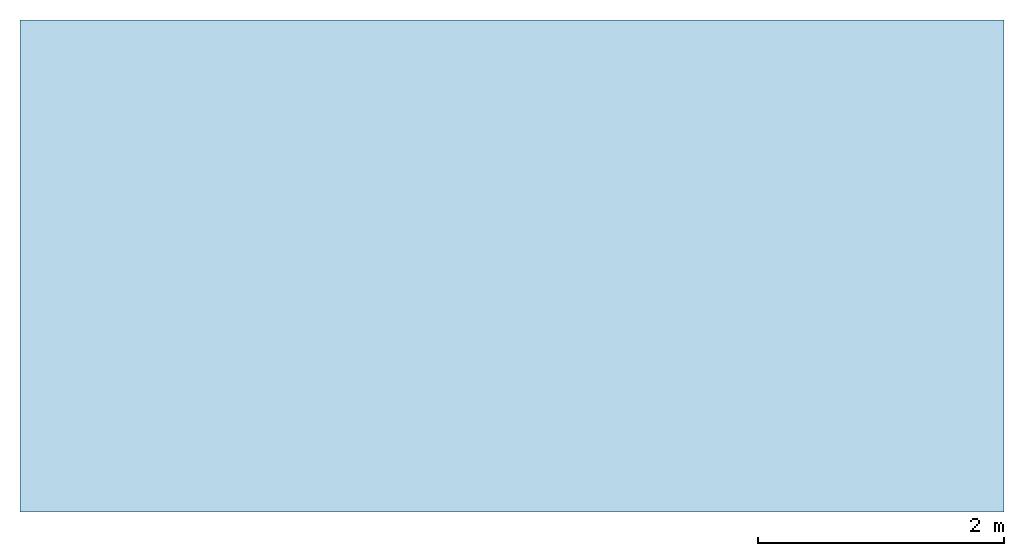
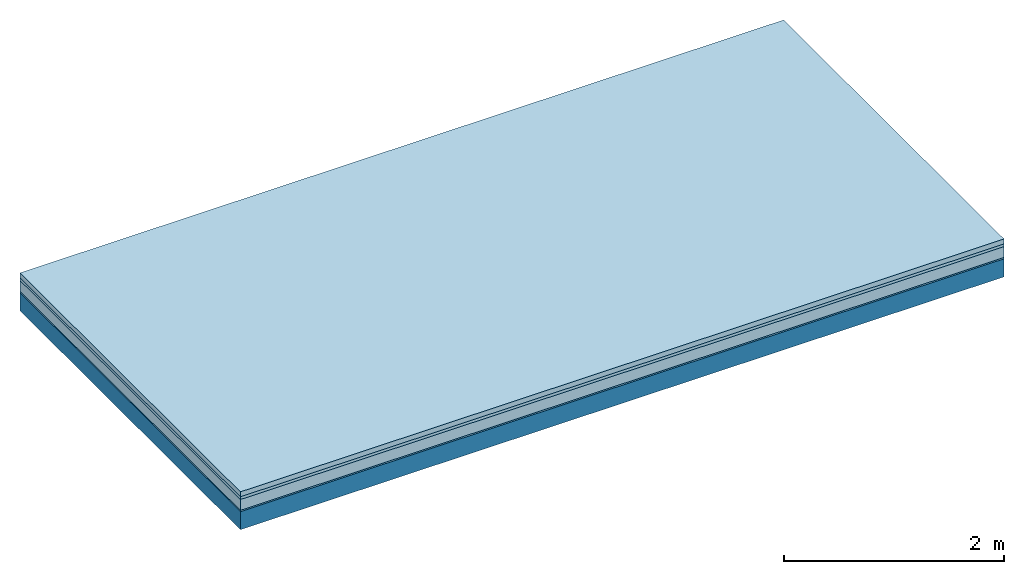
# One storey: 4 plates, 1 member, 1 element without a shape of its own.
"""IFC4 building model written with IfcOpenShell, lengths in metres."""

from ifc_helpers import new_model, si_unit, derived_unit, direction, frame, frame_2d, origin, origin_with_axes, place, context, project, spatial, rectangle, extrude, material, layer, layer_set, type_object, element, aggregate, save


model = new_model("IFC4")

# Units and contexts
plan_context = context("Plan", 3, precision=1e-05, world=origin(), true_north=direction((0.0, 1.0)))
model_context = context("Model", 3, precision=1e-05, world=origin(), true_north=direction((0.0, 1.0)))
ifc_project = project(units=[si_unit("LENGTHUNIT", "METRE"), derived_unit("SOUNDPRESSUREUNIT", [(si_unit("PRESSUREUNIT", "PASCAL", prefix="MICRO"), 0)]), si_unit("ENERGYUNIT", "JOULE", prefix="MEGA"), si_unit("MASSUNIT", "GRAM", prefix="KILO"), derived_unit("THERMALTRANSMITTANCEUNIT", [(si_unit("POWERUNIT", "WATT"), 1), (si_unit("AREAUNIT", "SQUARE_METRE"), -1), (si_unit("THERMODYNAMICTEMPERATUREUNIT", "KELVIN"), -1)]), derived_unit("AREADENSITYUNIT", [(si_unit("MASSUNIT", "GRAM", prefix="KILO"), 1), (si_unit("AREAUNIT", "SQUARE_METRE"), -1)]), derived_unit("USERDEFINED", [(si_unit("ENERGYUNIT", "JOULE", prefix="MEGA"), 1), (si_unit("AREAUNIT", "SQUARE_METRE"), -1)])], contexts=[plan_context, model_context])

# Site, building, storey
site = spatial("IfcSite", under=ifc_project)
building_placement = place(None, origin())
building = spatial("IfcBuilding", under=site, at=building_placement)
storey_placement = place(building_placement, origin())
storey = spatial("IfcBuildingStorey", under=building, at=storey_placement)

# Slab, member, plates
ifc_material_1 = material(Category="04.005")
ifc_layer_1 = layer(ifc_material_1, 0.055, Name="On-material")
ifc_material_2 = material()
ifc_layer_2 = layer(ifc_material_2, 0.03, Name="Impact sound insulation")
ifc_material_3 = material(Category="03.011")
ifc_layer_3 = layer(ifc_material_3, 0.12, Name="on Supporting structure")
ifc_material_4 = material(Category="03.007")
ifc_layer_4 = layer(ifc_material_4, 0.015, Name="Sub-floor")
ifc_material_5 = material(Name="of the art")
ifc_layer_5 = layer(ifc_material_5, 0.0, Name="Bond")
ifc_layer_6 = layer(None, 0.2, Name="Supporting structure")
ifc_layer_set = layer_set([ifc_layer_1, ifc_layer_2, ifc_layer_3, ifc_layer_4, ifc_layer_5, ifc_layer_6])
slab_type = type_object("IfcSlabType", Name="A1105", PredefinedType="NOTDEFINED", material=ifc_layer_set)
slab_placement = place(None, frame((0.0, 0.0, 0.0), z_axis=(0.0, 0.0, -1.0), x_axis=(1.0, 0.0, 0.0)))
slab = element("IfcSlab", 1, at=slab_placement, inside=storey, type_object=slab_type, material=ifc_layer_set, Name="Slab #1")
ifc_material_6 = material()
member_placement = place(slab_placement, origin())
member = element("IfcMember", 2, at=member_placement, material=ifc_material_6, Name="Supporting structure", context=plan_context, shape_type="SweptSolid", body=[
    extrude(rectangle(XDim=1.0, YDim=0.2, at=frame_2d((0.5, 0.1), x_axis=(1.0, 0.0))), frame((0.0, 4.0, 0.22), z_axis=(0.0, -1.0, 0.0), x_axis=(1.0, 0.0, 0.0)), (0.0, 0.0, 1.0), 4.0),
    extrude(rectangle(XDim=1.0, YDim=0.2, at=frame_2d((0.5, 0.1), x_axis=(1.0, 0.0))), frame((1.0, 4.0, 0.22), z_axis=(0.0, -1.0, 0.0), x_axis=(1.0, 0.0, 0.0)), (0.0, 0.0, 1.0), 4.0),
    extrude(rectangle(XDim=1.0, YDim=0.2, at=frame_2d((0.5, 0.1), x_axis=(1.0, 0.0))), frame((2.0, 4.0, 0.22), z_axis=(0.0, -1.0, 0.0), x_axis=(1.0, 0.0, 0.0)), (0.0, 0.0, 1.0), 4.0),
    extrude(rectangle(XDim=1.0, YDim=0.2, at=frame_2d((0.5, 0.1), x_axis=(1.0, 0.0))), frame((3.0, 4.0, 0.22), z_axis=(0.0, -1.0, 0.0), x_axis=(1.0, 0.0, 0.0)), (0.0, 0.0, 1.0), 4.0),
    extrude(rectangle(XDim=1.0, YDim=0.2, at=frame_2d((0.5, 0.1), x_axis=(1.0, 0.0))), frame((4.0, 4.0, 0.22), z_axis=(0.0, -1.0, 0.0), x_axis=(1.0, 0.0, 0.0)), (0.0, 0.0, 1.0), 4.0),
    extrude(rectangle(XDim=1.0, YDim=0.2, at=frame_2d((0.5, 0.1), x_axis=(1.0, 0.0))), frame((5.0, 4.0, 0.22), z_axis=(0.0, -1.0, 0.0), x_axis=(1.0, 0.0, 0.0)), (0.0, 0.0, 1.0), 4.0),
    extrude(rectangle(XDim=1.0, YDim=0.2, at=frame_2d((0.5, 0.1), x_axis=(1.0, 0.0))), frame((6.0, 4.0, 0.22), z_axis=(0.0, -1.0, 0.0), x_axis=(1.0, 0.0, 0.0)), (0.0, 0.0, 1.0), 4.0),
    extrude(rectangle(XDim=1.0, YDim=0.2, at=frame_2d((0.5, 0.1), x_axis=(1.0, 0.0))), frame((7.0, 4.0, 0.22), z_axis=(0.0, -1.0, 0.0), x_axis=(1.0, 0.0, 0.0)), (0.0, 0.0, 1.0), 4.0),
])
plate_1_placement = place(slab_placement, origin())
plate_1 = element("IfcPlate", 3, at=plate_1_placement, material=ifc_material_1, Name="On-material", context=plan_context, shape_type="SweptSolid", body=[
    extrude(rectangle(XDim=8.0, YDim=4.0, at=frame_2d((4.0, 2.0), x_axis=(1.0, 0.0))), origin_with_axes(), (0.0, 0.0, 1.0), 0.055),
])
plate_2_placement = place(slab_placement, origin())
plate_2 = element("IfcPlate", 4, at=plate_2_placement, material=ifc_material_2, Name="Impact sound insulation", context=plan_context, shape_type="SweptSolid", body=[
    extrude(rectangle(XDim=8.0, YDim=4.0, at=frame_2d((4.0, 2.0), x_axis=(1.0, 0.0))), frame((0.0, 0.0, 0.055), z_axis=(0.0, 0.0, 1.0), x_axis=(1.0, 0.0, 0.0)), (0.0, 0.0, 1.0), 0.03),
])
plate_3_placement = place(slab_placement, origin())
plate_3 = element("IfcPlate", 5, at=plate_3_placement, material=ifc_material_3, Name="on Supporting structure", context=plan_context, shape_type="SweptSolid", body=[
    extrude(rectangle(XDim=8.0, YDim=4.0, at=frame_2d((4.0, 2.0), x_axis=(1.0, 0.0))), frame((0.0, 0.0, 0.085), z_axis=(0.0, 0.0, 1.0), x_axis=(1.0, 0.0, 0.0)), (0.0, 0.0, 1.0), 0.12),
])
plate_4_placement = place(slab_placement, origin())
plate_4 = element("IfcPlate", 6, at=plate_4_placement, material=ifc_material_4, Name="Sub-floor", context=plan_context, shape_type="SweptSolid", body=[
    extrude(rectangle(XDim=8.0, YDim=4.0, at=frame_2d((4.0, 2.0), x_axis=(1.0, 0.0))), frame((0.0, 0.0, 0.205), z_axis=(0.0, 0.0, 1.0), x_axis=(1.0, 0.0, 0.0)), (0.0, 0.0, 1.0), 0.015),
])
aggregate(slab, [plate_1, plate_2, plate_3, plate_4, member])

save(model, "model.ifc")
